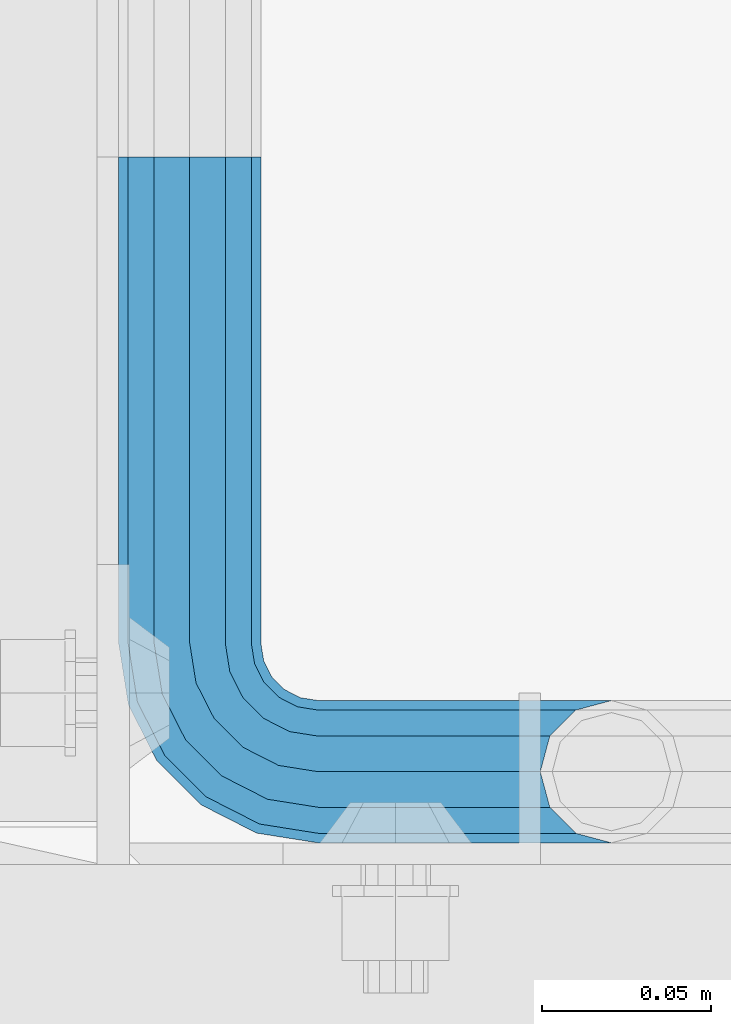
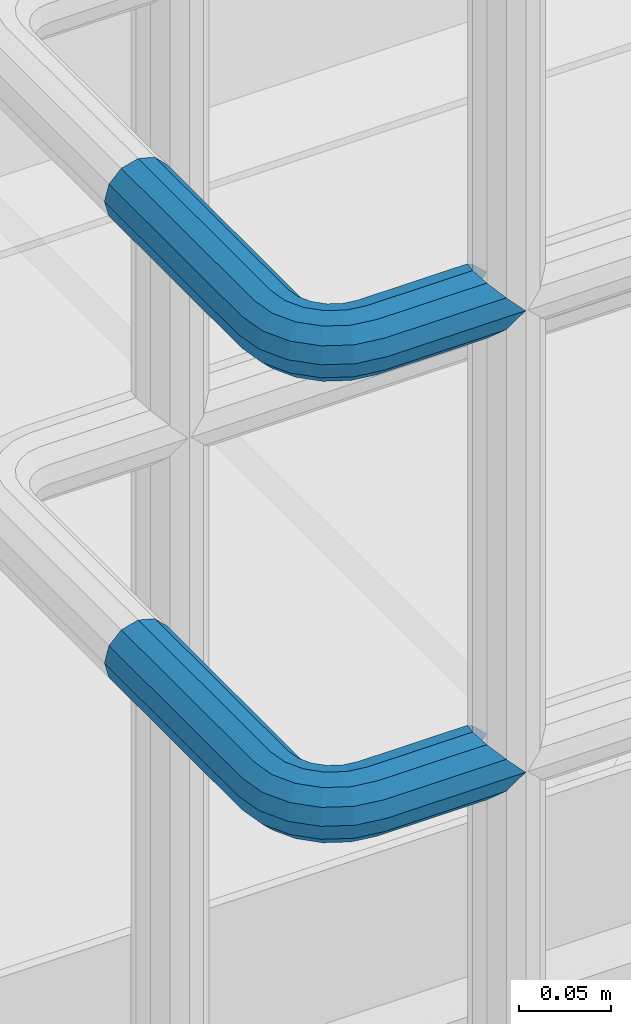
# One storey, part 1117 of 1876: 2 beams, 1 element without a shape of its own.
"""IFC2X3 building model written with IfcOpenShell, lengths in millimetres."""

from ifc_helpers import new_model, si_unit, frame, origin_with_axes, place, context, subcontext, project, spatial, faceted_brep, material, type_object, element, aggregate, save


model = new_model("IFC2X3")

# Units and contexts
model_context = context("Model", 3, precision=1e-05, world=origin_with_axes())
body_context = subcontext(model_context, "Body", "Model", "MODEL_VIEW")
ifc_project = project(units=[si_unit("LENGTHUNIT", "METRE", prefix="MILLI"), si_unit("AREAUNIT", "SQUARE_METRE"), si_unit("VOLUMEUNIT", "CUBIC_METRE"), si_unit("MASSUNIT", "GRAM", prefix="KILO"), si_unit("TIMEUNIT", "SECOND"), si_unit("PLANEANGLEUNIT", "RADIAN"), si_unit("SOLIDANGLEUNIT", "STERADIAN"), si_unit("THERMODYNAMICTEMPERATUREUNIT", "DEGREE_CELSIUS"), si_unit("LUMINOUSINTENSITYUNIT", "LUMEN")], contexts=[model_context])

# Site, building, storey
site_placement = place(None, origin_with_axes())
site = spatial("IfcSite", under=ifc_project, at=site_placement, CompositionType="ELEMENT")
building_placement = place(site_placement, origin_with_axes())
building = spatial("IfcBuilding", under=site, at=building_placement, Name="Undefined", CompositionType="ELEMENT")
storey_placement = place(building_placement, origin_with_axes())
storey = spatial("IfcBuildingStorey", under=building, at=storey_placement, Name="Undefined", CompositionType="ELEMENT", Elevation=0.0)

# Assembly, beams
assembly_placement = place(storey_placement, origin_with_axes())
assembly = element("IfcElementAssembly", 1, at=assembly_placement, inside=storey, Name="HANDRAIL", AssemblyPlace="NOTDEFINED", PredefinedType="RIGID_FRAME")
ifc_material = material()
beam_type = type_object("IfcBeamType", Name="PIPE1-1/4STD", PredefinedType="NOTDEFINED")
beam_1_placement = place(assembly_placement, frame((5666.23343150122, -11563.31485742, 8480.425), z_axis=(0.0, 0.0, -1.0), x_axis=(0.0, -1.0, 0.0)))
beam_1 = element("IfcBeam", 2, at=beam_1_placement, type_object=beam_type, material=ifc_material, Name="HANDRAIL", ObjectType="PIPE1-1/4STD", context=body_context, shape_type="Brep", body=[
    faceted_brep([(161.035599487304, -124.968002319336, 0.0), (163.860051924721, -114.42699926758, -10.5409999999993), (163.860051924721, -114.42699926758, 10.5409999999993), (190.880599487306, -106.234039250904, -15.1779612267255), (182.117599487305, -103.88599926758, -17.5259999999998), (182.117599487305, -103.88599926758, -21.0820000000003), (192.658599487306, -106.710451704997, -18.2575475625836), (192.658594971335, -106.710451704997, -13.3999657426939), (173.354599487306, -106.234036830804, -15.1779612267255), (171.576594971337, -106.710451704997, -13.3999567107567), (171.576599487305, -106.710451704997, -18.2575475625836), (166.939638260579, -111.347408415754, -8.76300000000083), (164.591599487305, -113.695447189028, 0.0), (166.939638260579, -111.347408415754, 8.76300000000083), (171.576594971337, -106.710451704997, 13.3999567107567), (171.576599487305, -106.710451704997, 18.2575475625836), (173.354599487306, -106.234036830804, 15.1779612267255), (182.117599487305, -103.88599926758, 17.5259999999998), (182.117599487305, -103.88599926758, 21.0820000000003), (190.880599487306, -106.234039250904, 15.1779612267255), (192.658594971335, -106.710451704997, 13.3999657426939), (192.658599487306, -106.710451704997, 18.2575475625836), (203.199594971336, -124.96799926758, 0.0), (200.375147049888, -114.42699926758, 10.5409999999993), (200.375147049888, -114.42699926758, -10.5409999999993), (197.29556071403, -111.347417447691, 8.76300000000083), (199.643599487305, -113.695456220966, 0.0), (197.29556071403, -111.347417447691, -8.76300000000083), (0.0, -18.2575475625836, -10.5409999999993), (0.0, -10.5410000000002, -18.2575475625836), (144.017601013184, -10.5410000000011, -18.2575475625836), (144.017601013184, -18.2575475625854, -10.5409999999993), (-4.28826751885936e-09, 0.0, -21.0820000000003), (144.017601013184, -1.81898940354586e-12, -21.0820000000003), (0.0, 10.5410000000002, -18.2575475625836), (144.017601013184, 10.5409999999983, -18.2575475625836), (0.0, 18.2575475625836, -10.5409999999993), (144.017601013184, 18.2575475625817, -10.5409999999993), (9.09494701772928e-13, 21.0820000000003, 0.0), (144.017601013184, 21.0819999999985, 0.0), (0.0, 18.2575475625836, 10.5409999999993), (144.017601013184, 18.2575475625817, 10.5409999999993), (0.0, 10.5410000000002, 18.2575475625836), (144.017601013184, 10.5409999999983, 18.2575475625836), (0.0, 0.0, 21.0820000000003), (144.017601013184, -1.81898940354586e-12, 21.0820000000003), (0.0, -10.5410000000002, 18.2575475625836), (144.017601013184, -10.5410000000011, 18.2575475625836), (0.0, -18.2575475625836, 10.5409999999993), (144.017601013184, -18.2575475625854, 10.5409999999993), (9.09494701772928e-13, -21.0820000000003, 0.0), (144.017601013184, -21.0820000000012, 0.0), (149.276451751935, -21.9149201310092, 0.0), (150.149255554901, -19.2287062354389, 10.5409999999993), (152.533799889643, -11.8898333927427, 18.2575475625836), (155.791148027351, -1.86474665447531, 21.0820000000003), (159.048496165058, 8.1603400837912, 18.2575475625836), (161.4330404998, 15.4992129264874, 10.5409999999993), (162.305844302766, 18.1854268220586, 0.0), (161.4330404998, 15.4992129264874, -10.5409999999993), (159.048496165058, 8.1603400837912, -18.2575475625836), (155.791148027351, -1.86474665447531, -21.0820000000003), (152.533799889643, -11.8898333927427, -18.2575475625836), (150.149255554901, -19.2287062354389, -10.5409999999993), (200.37514704989, -38.099998474122, -10.5409999999993), (203.199599487307, -38.099998474122, 0.0), (182.117599487307, -38.099998474122, -21.0820000000003), (192.658599487306, -38.099998474122, -18.2575475625836), (171.576599487307, -38.0999984741229, -18.2575475625836), (163.860051924723, -38.0999984741229, -10.5409999999993), (161.035599487304, -38.0999984741229, 0.0), (163.860051924723, -38.0999984741229, 10.5409999999993), (171.576599487307, -38.0999984741229, 18.2575475625836), (182.117599487307, -38.099998474122, 21.0820000000003), (192.658599487306, -38.099998474122, 18.2575475625836), (200.37514704989, -38.099998474122, 10.5409999999993), (197.616812413795, -20.6845589875047, -10.5409999999993), (190.277939571099, -23.0691033222465, -18.2575475625836), (200.303026309366, -19.811755184538, 0.0), (197.616812413795, -20.6845589875047, 10.5409999999993), (190.277939571099, -23.0691033222465, 18.2575475625836), (180.252852832831, -26.3264514599541, 21.0820000000003), (170.227766094566, -29.5837995976626, 18.2575475625836), (162.888893251869, -31.9683439324044, 10.5409999999993), (160.202679356298, -32.8411477353702, 0.0), (162.888893251869, -31.9683439324044, -10.5409999999993), (170.227766094566, -29.5837995976626, -18.2575475625836), (180.252852832831, -26.3264514599541, -21.0820000000003), (183.368995402116, -9.50953691425457, -18.2575475625836), (174.841147264409, -15.7053812586691, -21.0820000000003), (189.611813518148, -4.97386405835459, -10.5409999999993), (191.896843539822, -3.31369256983999, 0.0), (189.611813518148, -4.97386405835459, 10.5409999999993), (183.368995402116, -9.50953691425457, 18.2575475625836), (174.841147264409, -15.7053812586691, 21.0820000000003), (166.313299126703, -21.9012256030846, 18.2575475625836), (160.070481010669, -26.4368984589846, 10.5409999999993), (157.785450988997, -28.0970699474992, 0.0), (160.070481010669, -26.4368984589846, -10.5409999999993), (166.313299126703, -21.9012256030846, -18.2575475625836), (166.412218228641, -7.27645222290084, -21.0820000000003), (160.216373884225, -15.8043003606062, -18.2575475625836), (172.608062573056, 1.25139591480547, -18.2575475625836), (177.143735428957, 7.49421403083761, -10.5409999999993), (178.803906917472, 9.77924405251179, 0.0), (177.143735428957, 7.49421403083761, 10.5409999999993), (172.608062573056, 1.25139591480547, 18.2575475625836), (166.412218228641, -7.27645222290084, 21.0820000000003), (160.216373884225, -15.8043003606062, 18.2575475625836), (155.680701028325, -22.0471184766393, 10.5409999999993), (154.02052953981, -24.3321484983126, 0.0), (155.680701028325, -22.0471184766393, -10.5409999999993), (0.0, -15.1779612267264, -8.76300000000083), (0.0, -8.76299999999992, -15.1779612267255), (0.0, 0.0, -17.5259999999998), (0.0, 8.76299999999992, -15.1779612267255), (0.0, 15.1779612267264, -8.76300000000083), (0.0, 17.5259999999998, 0.0), (0.0, 15.1779612267264, 8.76300000000083), (0.0, 8.76299999999992, 15.1779612267255), (0.0, 0.0, 17.5259999999998), (0.0, -8.76299999999992, 15.1779612267255), (0.0, -15.1779612267264, 8.76300000000083), (0.0, -17.5259999999998, 0.0), (144.017601013184, 8.76299999999901, -15.1779612267255), (144.017601013184, 15.1779612267246, -8.76300000000083), (144.017601013184, 17.5259999999989, 0.0), (144.017601013184, 15.1779612267246, 8.76300000000083), (144.017601013184, 8.76299999999901, 15.1779612267255), (144.017601013184, -1.81898940354586e-12, 17.5259999999998), (144.017601013184, -8.76300000000174, 15.1779612267255), (144.017601013184, -15.1779612267273, 8.76300000000083), (144.017601013184, -17.5260000000017, 0.0), (144.017601013184, -15.1779612267273, -8.76300000000083), (144.017601013184, -8.76300000000174, -15.1779612267255), (144.017601013184, -1.81898940354586e-12, -17.5259999999998), (155.791148027351, -1.86474665447531, -17.5259999999998), (158.499063949059, 6.46936159781853, -15.1779612267255), (160.481395986375, 12.570352274277, -8.76300000000083), (161.206979870767, 14.8034698501133, 0.0), (160.481395986375, 12.570352274277, 8.76300000000083), (158.499063949059, 6.46936159781853, 15.1779612267255), (155.791148027351, -1.86474665447531, 17.5259999999998), (153.083232105642, -10.1988549067692, 15.1779612267255), (151.100900068326, -16.2998455832276, 8.76300000000083), (150.375316183934, -18.5329631590639, 0.0), (151.100900068326, -16.2998455832276, -8.76300000000083), (153.083232105642, -10.1988549067701, -15.1779612267255), (161.261456062801, -14.3658681446077, -15.1779612267255), (166.412218228641, -7.27645222290084, -17.5259999999998), (157.490836459703, -19.5556807952853, -8.76300000000083), (156.110693896962, -21.4552840663155, 0.0), (157.490836459703, -19.5556807952853, 8.76300000000083), (161.261456062801, -14.3658681446077, 15.1779612267255), (166.412218228641, -7.27645222290084, 17.5259999999998), (171.562980394479, -0.187036301193075, 15.1779612267255), (175.333599997579, 5.00277634948452, 8.76300000000083), (176.71374256032, 6.90237962051469, 0.0), (175.333599997579, 5.00277634948452, -8.76300000000083), (171.562980394479, -0.187036301193075, -15.1779612267255), (174.841147264409, -15.7053812586691, -17.5259999999998), (181.930563186117, -10.5546190928308, -15.1779612267255), (167.751731342702, -20.8561434245084, -15.1779612267255), (162.561918692023, -24.6267630276061, -8.76300000000083), (160.662315420994, -26.0069055903468, 0.0), (162.561918692023, -24.6267630276061, 8.76300000000083), (167.751731342702, -20.8561434245084, 15.1779612267255), (174.841147264409, -15.7053812586691, 17.5259999999998), (181.930563186117, -10.5546190928308, 15.1779612267255), (187.120375836796, -6.78399948973311, 8.76300000000083), (189.019979107825, -5.40385692699238, 0.0), (187.120375836796, -6.78399948973311, -8.76300000000083), (188.586961085126, -23.6185355382449, -15.1779612267255), (194.687951761583, -21.6362035009297, -8.76300000000083), (180.252852832831, -26.3264514599541, -17.5259999999998), (171.918744580538, -29.0343673816633, -15.1779612267255), (165.817753904079, -31.0166994189794, -8.76300000000083), (163.584636328244, -31.7422833033725, 0.0), (165.817753904079, -31.0166994189794, 8.76300000000083), (171.918744580538, -29.0343673816633, 15.1779612267255), (180.252852832831, -26.3264514599541, 17.5259999999998), (188.586961085126, -23.6185355382449, 15.1779612267255), (194.687951761583, -21.6362035009297, 8.76300000000083), (196.921069337421, -20.9106196165367, 0.0), (197.295560714032, -38.099998474122, -8.76300000000083), (199.643599487306, -38.099998474122, 0.0), (190.880599487307, -38.099998474122, -15.1779612267255), (182.117599487307, -38.099998474122, -17.5259999999998), (173.354599487306, -38.0999984741229, -15.1779612267255), (166.939638260581, -38.0999984741229, -8.76300000000083), (164.591599487305, -38.0999984741229, 0.0), (166.939638260581, -38.0999984741229, 8.76300000000083), (173.354599487306, -38.0999984741229, 15.1779612267255), (182.117599487307, -38.099998474122, 17.5259999999998), (190.880599487307, -38.099998474122, 15.1779612267255), (197.295560714032, -38.099998474122, 8.76300000000083)], [[[0, 1, 2]], [[3, 4, 5, 6, 7]], [[8, 9, 10, 5, 4]], [[2, 1, 10, 9, 11, 12, 13, 14, 15]], [[15, 14, 16, 17, 18]], [[18, 17, 19, 20, 21]], [[22, 23, 24]], [[21, 20, 25, 26, 27, 7, 6, 24, 23]], [[28, 29, 30, 31]], [[29, 32, 33, 30]], [[32, 34, 35, 33]], [[34, 36, 37, 35]], [[36, 38, 39, 37]], [[38, 40, 41, 39]], [[40, 42, 43, 41]], [[42, 44, 45, 43]], [[44, 46, 47, 45]], [[46, 48, 49, 47]], [[48, 50, 51, 49]], [[49, 51, 52, 53]], [[47, 49, 53, 54]], [[45, 47, 54, 55]], [[43, 45, 55, 56]], [[41, 43, 56, 57]], [[39, 41, 57, 58]], [[37, 39, 58, 59]], [[35, 37, 59, 60]], [[33, 35, 60, 61]], [[30, 33, 61, 62]], [[31, 30, 62, 63]], [[64, 65, 22, 24]], [[66, 67, 6, 5]], [[68, 66, 5, 10]], [[69, 68, 10, 1]], [[70, 69, 1, 0]], [[71, 70, 0, 2]], [[72, 71, 2, 15]], [[73, 72, 15, 18]], [[74, 73, 18, 21]], [[75, 74, 21, 23]], [[65, 75, 23, 22]], [[67, 64, 24, 6]], [[76, 64, 67, 77]], [[78, 65, 64, 76]], [[79, 75, 65, 78]], [[80, 74, 75, 79]], [[81, 73, 74, 80]], [[82, 72, 73, 81]], [[83, 71, 72, 82]], [[84, 70, 71, 83]], [[85, 69, 70, 84]], [[86, 68, 69, 85]], [[87, 66, 68, 86]], [[77, 67, 66, 87]], [[88, 77, 87, 89]], [[90, 76, 77, 88]], [[91, 78, 76, 90]], [[92, 79, 78, 91]], [[93, 80, 79, 92]], [[94, 81, 80, 93]], [[95, 82, 81, 94]], [[96, 83, 82, 95]], [[97, 84, 83, 96]], [[98, 85, 84, 97]], [[99, 86, 85, 98]], [[89, 87, 86, 99]], [[100, 89, 99, 101]], [[102, 88, 89, 100]], [[103, 90, 88, 102]], [[104, 91, 90, 103]], [[105, 92, 91, 104]], [[106, 93, 92, 105]], [[107, 94, 93, 106]], [[108, 95, 94, 107]], [[109, 96, 95, 108]], [[110, 97, 96, 109]], [[111, 98, 97, 110]], [[101, 99, 98, 111]], [[62, 101, 111, 63]], [[61, 100, 101, 62]], [[60, 102, 100, 61]], [[59, 103, 102, 60]], [[58, 104, 103, 59]], [[57, 105, 104, 58]], [[56, 106, 105, 57]], [[55, 107, 106, 56]], [[54, 108, 107, 55]], [[53, 109, 108, 54]], [[52, 110, 109, 53]], [[63, 111, 110, 52]], [[51, 31, 63, 52]], [[50, 28, 31, 51]], [[48, 46, 44, 42, 40, 38, 36, 34, 32, 29, 28, 50], [112, 113, 114, 115, 116, 117, 118, 119, 120, 121, 122, 123]], [[116, 115, 124, 125]], [[117, 116, 125, 126]], [[118, 117, 126, 127]], [[119, 118, 127, 128]], [[120, 119, 128, 129]], [[121, 120, 129, 130]], [[122, 121, 130, 131]], [[123, 122, 131, 132]], [[112, 123, 132, 133]], [[113, 112, 133, 134]], [[114, 113, 134, 135]], [[115, 114, 135, 124]], [[124, 135, 136, 137]], [[125, 124, 137, 138]], [[126, 125, 138, 139]], [[127, 126, 139, 140]], [[128, 127, 140, 141]], [[129, 128, 141, 142]], [[130, 129, 142, 143]], [[131, 130, 143, 144]], [[132, 131, 144, 145]], [[133, 132, 145, 146]], [[134, 133, 146, 147]], [[135, 134, 147, 136]], [[147, 148, 149, 136]], [[146, 150, 148, 147]], [[145, 151, 150, 146]], [[144, 152, 151, 145]], [[143, 153, 152, 144]], [[142, 154, 153, 143]], [[141, 155, 154, 142]], [[140, 156, 155, 141]], [[139, 157, 156, 140]], [[138, 158, 157, 139]], [[137, 159, 158, 138]], [[136, 149, 159, 137]], [[149, 160, 161, 159]], [[148, 162, 160, 149]], [[150, 163, 162, 148]], [[151, 164, 163, 150]], [[152, 165, 164, 151]], [[153, 166, 165, 152]], [[154, 167, 166, 153]], [[155, 168, 167, 154]], [[156, 169, 168, 155]], [[157, 170, 169, 156]], [[158, 171, 170, 157]], [[159, 161, 171, 158]], [[161, 172, 173, 171]], [[160, 174, 172, 161]], [[162, 175, 174, 160]], [[163, 176, 175, 162]], [[164, 177, 176, 163]], [[165, 178, 177, 164]], [[166, 179, 178, 165]], [[167, 180, 179, 166]], [[168, 181, 180, 167]], [[169, 182, 181, 168]], [[170, 183, 182, 169]], [[171, 173, 183, 170]], [[173, 184, 185, 183]], [[172, 186, 184, 173]], [[174, 187, 186, 172]], [[175, 188, 187, 174]], [[176, 189, 188, 175]], [[177, 190, 189, 176]], [[178, 191, 190, 177]], [[179, 192, 191, 178]], [[180, 193, 192, 179]], [[181, 194, 193, 180]], [[182, 195, 194, 181]], [[183, 185, 195, 182]], [[195, 185, 26, 25]], [[19, 194, 195, 25, 20]], [[193, 194, 19, 17]], [[192, 193, 17, 16]], [[13, 191, 192, 16, 14]], [[190, 191, 13, 12]], [[189, 190, 12, 11]], [[188, 189, 11, 9, 8]], [[187, 188, 8, 4]], [[186, 187, 4, 3]], [[184, 186, 3, 7, 27]], [[185, 184, 27, 26]]]),
])
beam_2_placement = place(assembly_placement, frame((5666.23343150122, -11563.31485742, 8785.225), z_axis=(0.0, 0.0, -1.0), x_axis=(0.0, -1.0, 0.0)))
beam_2 = element("IfcBeam", 3, at=beam_2_placement, type_object=beam_type, material=ifc_material, Name="HANDRAIL", ObjectType="PIPE1-1/4STD", context=body_context, shape_type="Brep", body=[
    faceted_brep([(161.035599487304, -124.968002319336, 0.0), (163.860051924721, -114.42699926758, -10.5409999999993), (163.860051924721, -114.42699926758, 10.5409999999993), (190.880599487306, -106.234039250904, -15.1779612267255), (182.117599487305, -103.88599926758, -17.5259999999998), (182.117599487305, -103.88599926758, -21.0820000000003), (192.658599487306, -106.710451704997, -18.2575475625836), (192.658594971335, -106.710451704997, -13.3999657426939), (173.354599487306, -106.234036830804, -15.1779612267255), (171.576594971337, -106.710451704997, -13.3999567107567), (171.576599487305, -106.710451704997, -18.2575475625836), (166.939638260579, -111.347408415754, -8.76300000000083), (164.591599487305, -113.695447189028, 0.0), (166.939638260579, -111.347408415754, 8.76300000000083), (171.576594971337, -106.710451704997, 13.3999567107567), (171.576599487305, -106.710451704997, 18.2575475625836), (173.354599487306, -106.234036830804, 15.1779612267255), (182.117599487305, -103.88599926758, 17.5259999999998), (182.117599487305, -103.88599926758, 21.0820000000003), (190.880599487306, -106.234039250904, 15.1779612267255), (192.658594971335, -106.710451704997, 13.3999657426939), (192.658599487306, -106.710451704997, 18.2575475625836), (203.199594971336, -124.96799926758, 0.0), (200.375147049888, -114.42699926758, 10.5409999999993), (200.375147049888, -114.42699926758, -10.5409999999993), (197.29556071403, -111.347417447691, 8.76300000000083), (199.643599487305, -113.695456220966, 0.0), (197.29556071403, -111.347417447691, -8.76300000000083), (0.0, -18.2575475625836, -10.5409999999993), (0.0, -10.5410000000002, -18.2575475625836), (144.017601013184, -10.5410000000011, -18.2575475625836), (144.017601013184, -18.2575475625854, -10.5409999999993), (-4.28826751885936e-09, 0.0, -21.0820000000003), (144.017601013184, -1.81898940354586e-12, -21.0820000000003), (0.0, 10.5410000000002, -18.2575475625836), (144.017601013184, 10.5409999999983, -18.2575475625836), (0.0, 18.2575475625836, -10.5409999999993), (144.017601013184, 18.2575475625817, -10.5409999999993), (9.09494701772928e-13, 21.0820000000003, 0.0), (144.017601013184, 21.0819999999985, 0.0), (0.0, 18.2575475625836, 10.5409999999993), (144.017601013184, 18.2575475625817, 10.5409999999993), (0.0, 10.5410000000002, 18.2575475625836), (144.017601013184, 10.5409999999983, 18.2575475625836), (0.0, 0.0, 21.0820000000003), (144.017601013184, -1.81898940354586e-12, 21.0820000000003), (0.0, -10.5410000000002, 18.2575475625836), (144.017601013184, -10.5410000000011, 18.2575475625836), (0.0, -18.2575475625836, 10.5409999999993), (144.017601013184, -18.2575475625854, 10.5409999999993), (9.09494701772928e-13, -21.0820000000003, 0.0), (144.017601013184, -21.0820000000012, 0.0), (149.276451751935, -21.9149201310092, 0.0), (150.149255554901, -19.2287062354389, 10.5409999999993), (152.533799889643, -11.8898333927427, 18.2575475625836), (155.791148027351, -1.86474665447531, 21.0820000000003), (159.048496165058, 8.1603400837912, 18.2575475625836), (161.4330404998, 15.4992129264874, 10.5409999999993), (162.305844302766, 18.1854268220586, 0.0), (161.4330404998, 15.4992129264874, -10.5409999999993), (159.048496165058, 8.1603400837912, -18.2575475625836), (155.791148027351, -1.86474665447531, -21.0820000000003), (152.533799889643, -11.8898333927427, -18.2575475625836), (150.149255554901, -19.2287062354389, -10.5409999999993), (200.37514704989, -38.099998474122, -10.5409999999993), (203.199599487307, -38.099998474122, 0.0), (182.117599487307, -38.099998474122, -21.0820000000003), (192.658599487306, -38.099998474122, -18.2575475625836), (171.576599487307, -38.0999984741229, -18.2575475625836), (163.860051924723, -38.0999984741229, -10.5409999999993), (161.035599487304, -38.0999984741229, 0.0), (163.860051924723, -38.0999984741229, 10.5409999999993), (171.576599487307, -38.0999984741229, 18.2575475625836), (182.117599487307, -38.099998474122, 21.0820000000003), (192.658599487306, -38.099998474122, 18.2575475625836), (200.37514704989, -38.099998474122, 10.5409999999993), (197.616812413795, -20.6845589875047, -10.5409999999993), (190.277939571099, -23.0691033222465, -18.2575475625836), (200.303026309366, -19.811755184538, 0.0), (197.616812413795, -20.6845589875047, 10.5409999999993), (190.277939571099, -23.0691033222465, 18.2575475625836), (180.252852832831, -26.3264514599541, 21.0820000000003), (170.227766094566, -29.5837995976626, 18.2575475625836), (162.888893251869, -31.9683439324044, 10.5409999999993), (160.202679356298, -32.8411477353702, 0.0), (162.888893251869, -31.9683439324044, -10.5409999999993), (170.227766094566, -29.5837995976626, -18.2575475625836), (180.252852832831, -26.3264514599541, -21.0820000000003), (183.368995402116, -9.50953691425457, -18.2575475625836), (174.841147264409, -15.7053812586691, -21.0820000000003), (189.611813518148, -4.97386405835459, -10.5409999999993), (191.896843539822, -3.31369256983999, 0.0), (189.611813518148, -4.97386405835459, 10.5409999999993), (183.368995402116, -9.50953691425457, 18.2575475625836), (174.841147264409, -15.7053812586691, 21.0820000000003), (166.313299126703, -21.9012256030846, 18.2575475625836), (160.070481010669, -26.4368984589846, 10.5409999999993), (157.785450988997, -28.0970699474992, 0.0), (160.070481010669, -26.4368984589846, -10.5409999999993), (166.313299126703, -21.9012256030846, -18.2575475625836), (166.412218228641, -7.27645222290084, -21.0820000000003), (160.216373884225, -15.8043003606062, -18.2575475625836), (172.608062573056, 1.25139591480547, -18.2575475625836), (177.143735428957, 7.49421403083761, -10.5409999999993), (178.803906917472, 9.77924405251179, 0.0), (177.143735428957, 7.49421403083761, 10.5409999999993), (172.608062573056, 1.25139591480547, 18.2575475625836), (166.412218228641, -7.27645222290084, 21.0820000000003), (160.216373884225, -15.8043003606062, 18.2575475625836), (155.680701028325, -22.0471184766393, 10.5409999999993), (154.02052953981, -24.3321484983126, 0.0), (155.680701028325, -22.0471184766393, -10.5409999999993), (0.0, -15.1779612267264, -8.76300000000083), (0.0, -8.76299999999992, -15.1779612267255), (0.0, 0.0, -17.5259999999998), (0.0, 8.76299999999992, -15.1779612267255), (0.0, 15.1779612267264, -8.76300000000083), (0.0, 17.5259999999998, 0.0), (0.0, 15.1779612267264, 8.76300000000083), (0.0, 8.76299999999992, 15.1779612267255), (0.0, 0.0, 17.5259999999998), (0.0, -8.76299999999992, 15.1779612267255), (0.0, -15.1779612267264, 8.76300000000083), (0.0, -17.5259999999998, 0.0), (144.017601013184, 8.76299999999901, -15.1779612267255), (144.017601013184, 15.1779612267246, -8.76300000000083), (144.017601013184, 17.5259999999989, 0.0), (144.017601013184, 15.1779612267246, 8.76300000000083), (144.017601013184, 8.76299999999901, 15.1779612267255), (144.017601013184, -1.81898940354586e-12, 17.5259999999998), (144.017601013184, -8.76300000000174, 15.1779612267255), (144.017601013184, -15.1779612267273, 8.76300000000083), (144.017601013184, -17.5260000000017, 0.0), (144.017601013184, -15.1779612267273, -8.76300000000083), (144.017601013184, -8.76300000000174, -15.1779612267255), (144.017601013184, -1.81898940354586e-12, -17.5259999999998), (155.791148027351, -1.86474665447531, -17.5259999999998), (158.499063949059, 6.46936159781853, -15.1779612267255), (160.481395986375, 12.570352274277, -8.76300000000083), (161.206979870767, 14.8034698501133, 0.0), (160.481395986375, 12.570352274277, 8.76300000000083), (158.499063949059, 6.46936159781853, 15.1779612267255), (155.791148027351, -1.86474665447531, 17.5259999999998), (153.083232105642, -10.1988549067692, 15.1779612267255), (151.100900068326, -16.2998455832276, 8.76300000000083), (150.375316183934, -18.5329631590639, 0.0), (151.100900068326, -16.2998455832276, -8.76300000000083), (153.083232105642, -10.1988549067701, -15.1779612267255), (161.261456062801, -14.3658681446077, -15.1779612267255), (166.412218228641, -7.27645222290084, -17.5259999999998), (157.490836459703, -19.5556807952853, -8.76300000000083), (156.110693896962, -21.4552840663155, 0.0), (157.490836459703, -19.5556807952853, 8.76300000000083), (161.261456062801, -14.3658681446077, 15.1779612267255), (166.412218228641, -7.27645222290084, 17.5259999999998), (171.562980394479, -0.187036301193075, 15.1779612267255), (175.333599997579, 5.00277634948452, 8.76300000000083), (176.71374256032, 6.90237962051469, 0.0), (175.333599997579, 5.00277634948452, -8.76300000000083), (171.562980394479, -0.187036301193075, -15.1779612267255), (174.841147264409, -15.7053812586691, -17.5259999999998), (181.930563186117, -10.5546190928308, -15.1779612267255), (167.751731342702, -20.8561434245084, -15.1779612267255), (162.561918692023, -24.6267630276061, -8.76300000000083), (160.662315420994, -26.0069055903468, 0.0), (162.561918692023, -24.6267630276061, 8.76300000000083), (167.751731342702, -20.8561434245084, 15.1779612267255), (174.841147264409, -15.7053812586691, 17.5259999999998), (181.930563186117, -10.5546190928308, 15.1779612267255), (187.120375836796, -6.78399948973311, 8.76300000000083), (189.019979107825, -5.40385692699238, 0.0), (187.120375836796, -6.78399948973311, -8.76300000000083), (188.586961085126, -23.6185355382449, -15.1779612267255), (194.687951761583, -21.6362035009297, -8.76300000000083), (180.252852832831, -26.3264514599541, -17.5259999999998), (171.918744580538, -29.0343673816633, -15.1779612267255), (165.817753904079, -31.0166994189794, -8.76300000000083), (163.584636328244, -31.7422833033725, 0.0), (165.817753904079, -31.0166994189794, 8.76300000000083), (171.918744580538, -29.0343673816633, 15.1779612267255), (180.252852832831, -26.3264514599541, 17.5259999999998), (188.586961085126, -23.6185355382449, 15.1779612267255), (194.687951761583, -21.6362035009297, 8.76300000000083), (196.921069337421, -20.9106196165367, 0.0), (197.295560714032, -38.099998474122, -8.76300000000083), (199.643599487306, -38.099998474122, 0.0), (190.880599487307, -38.099998474122, -15.1779612267255), (182.117599487307, -38.099998474122, -17.5259999999998), (173.354599487306, -38.0999984741229, -15.1779612267255), (166.939638260581, -38.0999984741229, -8.76300000000083), (164.591599487305, -38.0999984741229, 0.0), (166.939638260581, -38.0999984741229, 8.76300000000083), (173.354599487306, -38.0999984741229, 15.1779612267255), (182.117599487307, -38.099998474122, 17.5259999999998), (190.880599487307, -38.099998474122, 15.1779612267255), (197.295560714032, -38.099998474122, 8.76300000000083)], [[[0, 1, 2]], [[3, 4, 5, 6, 7]], [[8, 9, 10, 5, 4]], [[2, 1, 10, 9, 11, 12, 13, 14, 15]], [[15, 14, 16, 17, 18]], [[18, 17, 19, 20, 21]], [[22, 23, 24]], [[21, 20, 25, 26, 27, 7, 6, 24, 23]], [[28, 29, 30, 31]], [[29, 32, 33, 30]], [[32, 34, 35, 33]], [[34, 36, 37, 35]], [[36, 38, 39, 37]], [[38, 40, 41, 39]], [[40, 42, 43, 41]], [[42, 44, 45, 43]], [[44, 46, 47, 45]], [[46, 48, 49, 47]], [[48, 50, 51, 49]], [[49, 51, 52, 53]], [[47, 49, 53, 54]], [[45, 47, 54, 55]], [[43, 45, 55, 56]], [[41, 43, 56, 57]], [[39, 41, 57, 58]], [[37, 39, 58, 59]], [[35, 37, 59, 60]], [[33, 35, 60, 61]], [[30, 33, 61, 62]], [[31, 30, 62, 63]], [[64, 65, 22, 24]], [[66, 67, 6, 5]], [[68, 66, 5, 10]], [[69, 68, 10, 1]], [[70, 69, 1, 0]], [[71, 70, 0, 2]], [[72, 71, 2, 15]], [[73, 72, 15, 18]], [[74, 73, 18, 21]], [[75, 74, 21, 23]], [[65, 75, 23, 22]], [[67, 64, 24, 6]], [[76, 64, 67, 77]], [[78, 65, 64, 76]], [[79, 75, 65, 78]], [[80, 74, 75, 79]], [[81, 73, 74, 80]], [[82, 72, 73, 81]], [[83, 71, 72, 82]], [[84, 70, 71, 83]], [[85, 69, 70, 84]], [[86, 68, 69, 85]], [[87, 66, 68, 86]], [[77, 67, 66, 87]], [[88, 77, 87, 89]], [[90, 76, 77, 88]], [[91, 78, 76, 90]], [[92, 79, 78, 91]], [[93, 80, 79, 92]], [[94, 81, 80, 93]], [[95, 82, 81, 94]], [[96, 83, 82, 95]], [[97, 84, 83, 96]], [[98, 85, 84, 97]], [[99, 86, 85, 98]], [[89, 87, 86, 99]], [[100, 89, 99, 101]], [[102, 88, 89, 100]], [[103, 90, 88, 102]], [[104, 91, 90, 103]], [[105, 92, 91, 104]], [[106, 93, 92, 105]], [[107, 94, 93, 106]], [[108, 95, 94, 107]], [[109, 96, 95, 108]], [[110, 97, 96, 109]], [[111, 98, 97, 110]], [[101, 99, 98, 111]], [[62, 101, 111, 63]], [[61, 100, 101, 62]], [[60, 102, 100, 61]], [[59, 103, 102, 60]], [[58, 104, 103, 59]], [[57, 105, 104, 58]], [[56, 106, 105, 57]], [[55, 107, 106, 56]], [[54, 108, 107, 55]], [[53, 109, 108, 54]], [[52, 110, 109, 53]], [[63, 111, 110, 52]], [[51, 31, 63, 52]], [[50, 28, 31, 51]], [[48, 46, 44, 42, 40, 38, 36, 34, 32, 29, 28, 50], [112, 113, 114, 115, 116, 117, 118, 119, 120, 121, 122, 123]], [[116, 115, 124, 125]], [[117, 116, 125, 126]], [[118, 117, 126, 127]], [[119, 118, 127, 128]], [[120, 119, 128, 129]], [[121, 120, 129, 130]], [[122, 121, 130, 131]], [[123, 122, 131, 132]], [[112, 123, 132, 133]], [[113, 112, 133, 134]], [[114, 113, 134, 135]], [[115, 114, 135, 124]], [[124, 135, 136, 137]], [[125, 124, 137, 138]], [[126, 125, 138, 139]], [[127, 126, 139, 140]], [[128, 127, 140, 141]], [[129, 128, 141, 142]], [[130, 129, 142, 143]], [[131, 130, 143, 144]], [[132, 131, 144, 145]], [[133, 132, 145, 146]], [[134, 133, 146, 147]], [[135, 134, 147, 136]], [[147, 148, 149, 136]], [[146, 150, 148, 147]], [[145, 151, 150, 146]], [[144, 152, 151, 145]], [[143, 153, 152, 144]], [[142, 154, 153, 143]], [[141, 155, 154, 142]], [[140, 156, 155, 141]], [[139, 157, 156, 140]], [[138, 158, 157, 139]], [[137, 159, 158, 138]], [[136, 149, 159, 137]], [[149, 160, 161, 159]], [[148, 162, 160, 149]], [[150, 163, 162, 148]], [[151, 164, 163, 150]], [[152, 165, 164, 151]], [[153, 166, 165, 152]], [[154, 167, 166, 153]], [[155, 168, 167, 154]], [[156, 169, 168, 155]], [[157, 170, 169, 156]], [[158, 171, 170, 157]], [[159, 161, 171, 158]], [[161, 172, 173, 171]], [[160, 174, 172, 161]], [[162, 175, 174, 160]], [[163, 176, 175, 162]], [[164, 177, 176, 163]], [[165, 178, 177, 164]], [[166, 179, 178, 165]], [[167, 180, 179, 166]], [[168, 181, 180, 167]], [[169, 182, 181, 168]], [[170, 183, 182, 169]], [[171, 173, 183, 170]], [[173, 184, 185, 183]], [[172, 186, 184, 173]], [[174, 187, 186, 172]], [[175, 188, 187, 174]], [[176, 189, 188, 175]], [[177, 190, 189, 176]], [[178, 191, 190, 177]], [[179, 192, 191, 178]], [[180, 193, 192, 179]], [[181, 194, 193, 180]], [[182, 195, 194, 181]], [[183, 185, 195, 182]], [[195, 185, 26, 25]], [[19, 194, 195, 25, 20]], [[193, 194, 19, 17]], [[192, 193, 17, 16]], [[13, 191, 192, 16, 14]], [[190, 191, 13, 12]], [[189, 190, 12, 11]], [[188, 189, 11, 9, 8]], [[187, 188, 8, 4]], [[186, 187, 4, 3]], [[184, 186, 3, 7, 27]], [[185, 184, 27, 26]]]),
])
aggregate(assembly, [beam_1, beam_2])

save(model, "model.ifc")
